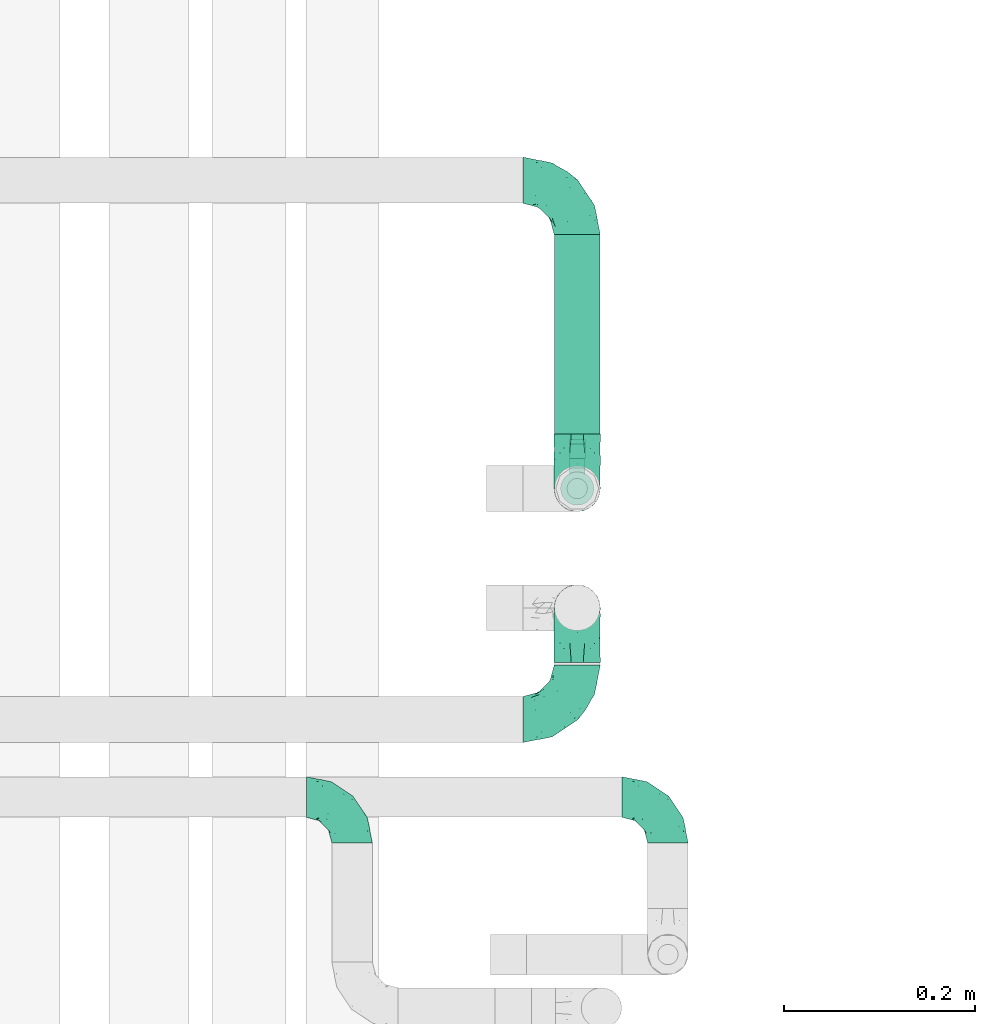
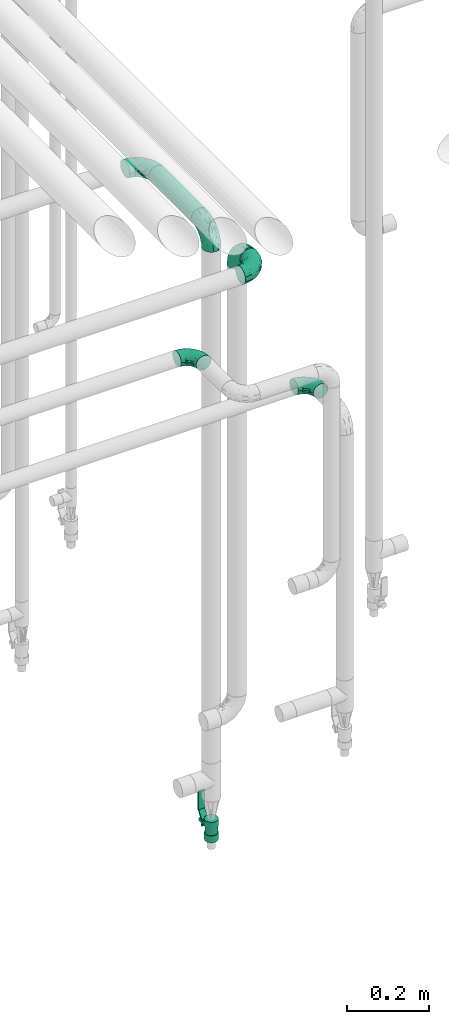
# One storey, part 577 of 827: 6 flow fittings, 1 flow controller, 1 flow segment.
"""IFC2X3 building model written with IfcOpenShell, lengths in millimetres."""

from ifc_helpers import new_model, entity, si_unit, converted_unit, derived_unit, direction, frame, origin, origin_2d_with_axis, place, context, subcontext, project, spatial, polyline, circle, outline, extrude, faceted_brep, source, transform, mapped, material, material_list, type_object, type_shapes, element, save


model = new_model("IFC2X3")

# Units and contexts
model_context = context("Model", 3, precision=0.01, world=origin(), true_north=direction((6.12303176911189e-17, 1.0)))
body_context = subcontext(model_context, "Body", "Model", "MODEL_VIEW")
ifc_project = project(units=[si_unit("LENGTHUNIT", "METRE", prefix="MILLI"), si_unit("AREAUNIT", "SQUARE_METRE"), si_unit("VOLUMEUNIT", "CUBIC_METRE"), converted_unit("PLANEANGLEUNIT", "DEGREE", entity("IfcRatioMeasure", 0.0174532925199433), si_unit("PLANEANGLEUNIT", "RADIAN"), dimensions=[0, 0, 0, 0, 0, 0, 0]), si_unit("MASSUNIT", "GRAM", prefix="KILO"), derived_unit("MASSDENSITYUNIT", [(si_unit("MASSUNIT", "GRAM", prefix="KILO"), 1), (si_unit("LENGTHUNIT", "METRE"), -3)]), derived_unit("MOMENTOFINERTIAUNIT", [(si_unit("LENGTHUNIT", "METRE"), 4)]), si_unit("TIMEUNIT", "SECOND"), si_unit("FREQUENCYUNIT", "HERTZ"), si_unit("THERMODYNAMICTEMPERATUREUNIT", "DEGREE_CELSIUS"), derived_unit("THERMALTRANSMITTANCEUNIT", [(si_unit("MASSUNIT", "GRAM", prefix="KILO"), 1), (si_unit("THERMODYNAMICTEMPERATUREUNIT", "KELVIN"), -1), (si_unit("TIMEUNIT", "SECOND"), -3)]), derived_unit("VOLUMETRICFLOWRATEUNIT", [(si_unit("LENGTHUNIT", "METRE"), 3), (si_unit("TIMEUNIT", "SECOND"), -1)]), derived_unit("MASSFLOWRATEUNIT", [(si_unit("MASSUNIT", "GRAM", prefix="KILO"), 1), (si_unit("TIMEUNIT", "SECOND"), -1)]), derived_unit("ROTATIONALFREQUENCYUNIT", [(si_unit("TIMEUNIT", "SECOND"), -1)]), si_unit("ELECTRICCURRENTUNIT", "AMPERE"), si_unit("ELECTRICVOLTAGEUNIT", "VOLT"), si_unit("POWERUNIT", "WATT"), si_unit("FORCEUNIT", "NEWTON", prefix="KILO"), si_unit("ILLUMINANCEUNIT", "LUX"), si_unit("LUMINOUSFLUXUNIT", "LUMEN"), si_unit("LUMINOUSINTENSITYUNIT", "CANDELA"), derived_unit("USERDEFINED", [(si_unit("MASSUNIT", "GRAM", prefix="KILO"), -1), (si_unit("LENGTHUNIT", "METRE"), -2), (si_unit("TIMEUNIT", "SECOND"), 3), (si_unit("LUMINOUSFLUXUNIT", "LUMEN"), 1)]), derived_unit("LINEARVELOCITYUNIT", [(si_unit("LENGTHUNIT", "METRE"), 1), (si_unit("TIMEUNIT", "SECOND"), -1)]), si_unit("PRESSUREUNIT", "PASCAL"), derived_unit("USERDEFINED", [(si_unit("LENGTHUNIT", "METRE"), -2), (si_unit("MASSUNIT", "GRAM", prefix="KILO"), 1), (si_unit("TIMEUNIT", "SECOND"), -2)]), derived_unit("LINEARFORCEUNIT", [(si_unit("MASSUNIT", "GRAM", prefix="KILO"), 1), (si_unit("LENGTHUNIT", "METRE"), 1), (si_unit("TIMEUNIT", "SECOND"), -2), (si_unit("LENGTHUNIT", "METRE"), -1)]), derived_unit("PLANARFORCEUNIT", [(si_unit("MASSUNIT", "GRAM", prefix="KILO"), 1), (si_unit("LENGTHUNIT", "METRE"), 1), (si_unit("TIMEUNIT", "SECOND"), -2), (si_unit("LENGTHUNIT", "METRE"), -2)])], contexts=[model_context])

# Site, building, storey
site_placement = place(None, origin())
site = spatial("IfcSite", under=ifc_project, at=site_placement, CompositionType="ELEMENT")
building_placement = place(site_placement, origin())
building = spatial("IfcBuilding", under=site, at=building_placement, CompositionType="ELEMENT")
storey_placement = place(building_placement, frame((0.0, 0.0, 28200.0)))
storey = spatial("IfcBuildingStorey", under=building, at=storey_placement, Name="08", CompositionType="ELEMENT", Elevation=28200.0)

# Flow segment
pipe_segment_type = type_object("IfcPipeSegmentType", PredefinedType="NOTDEFINED")
flow_segment_placement = place(storey_placement, frame((18903.46, 15687.01, 2070.34)))
element("IfcFlowSegment", 1, at=flow_segment_placement, inside=storey, type_object=pipe_segment_type, context=body_context, shape_type="SweptSolid", body=[
    extrude(circle(Radius=24.0, at=origin_2d_with_axis()), frame((25.6, 0.0, 25.6), z_axis=(0.0, 1.0, 0.0), x_axis=(1.0, 0.0, 0.0)), (0.0, 0.0, 1.0), 209.080000228861),
])

# Flow controller
ifc_material = material()
ifc_material_list = material_list([ifc_material, ifc_material, ifc_material, ifc_material, ifc_material])
valve_type = type_object("IfcValveType", PredefinedType="NOTDEFINED", material=ifc_material_list)
shared_shape_1 = source(origin(), body_context, "Body", "SweptSolid", [
    extrude(circle(Radius=17.5, at=origin_2d_with_axis()), frame((-30.5, 0.0, 0.0), z_axis=(1.0, 0.0, 0.0), x_axis=(0.0, 1.0, 0.0)), (0.0, 0.0, 1.0), 20.3333333333333),
    extrude(circle(Radius=16.0, at=origin_2d_with_axis()), frame((-10.17, 0.0, 0.0), z_axis=(1.0, 0.0, 0.0), x_axis=(0.0, 1.0, 0.0)), (0.0, 0.0, 1.0), 20.3333333333333),
    extrude(circle(Radius=17.5, at=origin_2d_with_axis()), frame((10.17, 0.0, 0.0), z_axis=(1.0, 0.0, 0.0), x_axis=(0.0, 1.0, 0.0)), (0.0, 0.0, 1.0), 20.3333333333333),
    extrude(outline(polyline([(-38.75, -5.0), (-38.75, -10.0), (-17.92, -10.0), (2.08, 5.0), (56.25, 5.0), (56.25, 10.0), (0.42, 10.0), (-19.58, -5.0), (-38.75, -5.0)])), frame((28.75, -8.75, 41.5), z_axis=(0.0, -1.0, 0.0), x_axis=(1.0, 0.0, 0.0)), (0.0, 0.0, -1.0), 17.5),
    extrude(circle(Radius=8.0, at=origin_2d_with_axis()), origin(), (0.0, 0.0, 1.0), 49.0),
])
type_shapes(valve_type, [shared_shape_1])
flow_controller_placement = place(storey_placement, frame((18929.06, 15630.01, 300.0), z_axis=(0.0, 1.0, 0.0), x_axis=(0.0, 0.0, 1.0)))
element("IfcFlowController", 2, at=flow_controller_placement, inside=storey, type_object=valve_type, material=ifc_material, context=body_context, shape_type="MappedRepresentation", body=[
    mapped(shared_shape_1, transform((0.0, 0.0, 0.0), scale=1.0)),
])

# Flow fittings
pipe_fitting_type_1 = type_object("IfcPipeFittingType", Name="ADSK_1", PredefinedType="NOTDEFINED", material=ifc_material)
shared_shape_2 = source(origin(), body_context, "Body", "Brep", [
    faceted_brep([(-57.0, 12.07, -20.91), (-57.0, 6.25, -23.33), (-57.0, 0.0, -24.15), (-57.0, -6.25, -23.33), (-57.0, -12.08, -20.91), (-57.0, -17.08, -17.08), (-57.0, -20.91, -12.08), (-57.0, -23.33, -6.25), (-57.0, -24.15, 0.0), (-57.0, -23.33, 6.25), (-57.0, -20.91, 12.07), (-57.0, -17.08, 17.08), (-57.0, -12.08, 20.91), (-57.0, -6.25, 23.33), (-57.0, 0.0, 24.15), (-57.0, 6.25, 23.33), (-57.0, 12.07, 20.91), (-57.0, 17.08, 17.08), (-57.0, 20.91, 12.07), (-57.0, 23.33, 6.25), (-57.0, 24.15, 0.0), (-57.0, 23.33, -6.25), (-57.0, 20.91, -12.08), (-57.0, 17.08, -17.08), (0.0, 57.0, -24.15), (-6.25, 57.0, -23.33), (-12.07, 57.0, -20.91), (-17.08, 57.0, -17.08), (-20.91, 57.0, -12.08), (-23.33, 57.0, -6.25), (-24.15, 57.0, 0.0), (-23.33, 57.0, 6.25), (-20.91, 57.0, 12.07), (-17.08, 57.0, 17.08), (-12.07, 57.0, 20.91), (-6.25, 57.0, 23.33), (0.0, 57.0, 24.15), (6.25, 57.0, 23.33), (12.08, 57.0, 20.91), (17.08, 57.0, 17.08), (20.91, 57.0, 12.07), (23.33, 57.0, 6.25), (24.15, 57.0, 0.0), (23.33, 57.0, -6.25), (20.91, 57.0, -12.08), (17.08, 57.0, -17.08), (12.08, 57.0, -20.91), (6.25, 57.0, -23.33), (14.9, 21.14, 6.17), (13.61, 24.64, 12.48), (6.23, 8.95, 8.98), (-41.47, -21.06, 0.0), (-41.92, -18.38, 13.72), (-24.64, -13.61, 12.48), (-37.37, -13.24, 18.15), (-6.8, -4.93, 8.18), (-21.76, -15.19, 6.22), (-12.78, -9.18, 0.0), (-37.73, -20.51, 7.75), (-7.38, 7.38, 20.24), (-23.37, -4.26, 20.42), (-11.9, -3.19, 15.86), (-42.14, -8.7, 21.82), (13.24, 37.37, 18.15), (9.33, 23.53, 16.85), (4.26, 23.37, 20.42), (2.77, 10.92, 15.55), (-29.46, 0.91, 23.52), (-44.13, 20.56, 15.69), (-39.25, 26.33, 10.88), (-49.02, 22.92, 9.96), (-34.58, 23.87, 17.15), (-15.8, 6.8, 22.81), (-8.67, 20.47, 23.88), (-18.12, 12.9, 24.08), (-48.29, 14.92, 19.65), (-44.06, -2.85, 23.78), (-9.23, 48.95, 22.58), (-3.78, 42.74, 24.07), (-40.34, 4.26, 24.09), (-44.02, 26.14, 5.46), (-44.04, 9.88, 22.74), (-4.95, 16.87, 22.52), (-2.75, 1.43, 12.5), (-25.48, 40.98, 10.71), (20.51, 37.73, 7.75), (18.38, 41.92, 13.72), (8.7, 42.14, 21.82), (-25.95, -17.97, 0.0), (2.85, 44.06, 23.78), (21.06, 41.47, 0.0), (17.97, 25.95, 0.0), (-24.04, -9.27, 17.13), (-33.26, 33.26, 5.86), (-28.55, 40.57, 0.0), (-40.57, 28.55, 0.0), (-25.29, 47.19, 4.06), (-27.01, 31.1, 16.77), (-15.7, 43.95, 19.9), (-20.27, 45.22, 15.61), (-30.53, 31.98, 12.64), (-11.28, 38.33, 22.92), (-9.97, 27.88, 24.09), (-20.15, 30.26, 21.25), (-31.25, 11.75, 23.64), (-28.75, 7.23, 24.15), (-29.53, 18.06, 22.27), (-28.44, 24.21, 20.02), (-37.55, 17.7, 20.26), (-15.88, 29.25, 22.99), (-20.82, 20.82, 23.44), (-0.91, 29.46, 23.52), (-13.5, -7.67, 12.04), (1.49, 1.56, 5.16), (8.86, 10.35, 4.59), (0.38, -0.38, 0.0), (9.18, 12.78, 0.0), (-37.37, -13.24, -18.15), (8.86, 10.35, -4.59), (-45.22, 20.27, -15.61), (-43.95, 15.7, -19.9), (-38.33, 11.28, -22.92), (-48.95, 9.23, -22.58), (-47.19, 25.29, -4.06), (-33.26, 33.26, -5.86), (18.38, 41.92, -13.72), (-30.26, 20.15, -21.25), (2.85, 44.06, -23.78), (-4.26, 40.34, -24.09), (-40.98, 25.48, -10.71), (-41.92, -18.38, -13.72), (9.25, 23.5, -16.92), (4.26, 23.37, -20.42), (13.24, 37.37, -18.15), (-37.73, -20.51, -7.75), (-11.75, 31.25, -23.64), (-7.23, 28.75, -24.15), (-12.9, 18.12, -24.08), (8.7, 42.14, -21.82), (-44.06, -2.85, -23.78), (-6.8, 15.8, -22.81), (-20.47, 8.67, -23.88), (-24.64, -13.61, -12.48), (-42.74, 3.78, -24.07), (-18.06, 29.53, -22.27), (-24.21, 28.44, -20.02), (-27.88, 9.97, -24.09), (-31.1, 27.01, -16.77), (-26.14, 44.02, -5.46), (14.9, 21.14, -6.17), (20.51, 37.73, -7.75), (-9.88, 44.04, -22.74), (-20.56, 44.13, -15.69), (-21.76, -15.19, -6.22), (-13.5, -7.67, -12.04), (-24.14, -9.76, -16.74), (-11.9, -3.19, -15.86), (-14.92, 48.29, -19.65), (-23.37, -4.26, -20.42), (-0.91, 29.46, -23.52), (-26.33, 39.25, -10.88), (-23.87, 34.58, -17.15), (-42.14, -8.7, -21.82), (-22.92, 49.02, -9.96), (13.61, 24.64, -12.48), (-31.98, 30.53, -12.64), (-16.87, 4.95, -22.52), (-17.7, 37.55, -20.26), (-29.25, 15.88, -22.99), (-20.82, 20.82, -23.44), (-29.46, 0.91, -23.52), (-7.38, 7.38, -20.24), (2.77, 10.92, -15.55), (6.23, 8.95, -8.98), (-6.8, -4.93, -8.18), (-2.81, 1.41, -12.54), (1.49, 1.56, -5.16)], [[[0, 1, 2, 3, 4, 5, 6, 7, 8, 9, 10, 11, 12, 13, 14, 15, 16, 17, 18, 19, 20, 21, 22, 23]], [[24, 25, 26, 27, 28, 29, 30, 31, 32, 33, 34, 35, 36, 37, 38, 39, 40, 41, 42, 43, 44, 45, 46, 47]], [[48, 49, 50]], [[9, 8, 51]], [[52, 53, 54]], [[55, 56, 57]], [[10, 58, 52]], [[9, 58, 10]], [[59, 60, 61]], [[54, 12, 11]], [[54, 62, 12]], [[63, 39, 38]], [[64, 65, 66]], [[62, 60, 67]], [[68, 69, 70]], [[71, 69, 68]], [[72, 73, 74]], [[16, 75, 17]], [[13, 76, 14]], [[35, 77, 78]], [[14, 79, 15]], [[17, 68, 18]], [[14, 76, 79]], [[20, 19, 80]], [[70, 19, 18]], [[81, 15, 79]], [[15, 81, 16]], [[73, 72, 82]], [[66, 83, 50]], [[32, 31, 84]], [[85, 86, 49]], [[63, 87, 65]], [[56, 58, 88]], [[36, 89, 37]], [[85, 41, 40]], [[36, 35, 78]], [[90, 41, 85]], [[40, 39, 86]], [[12, 62, 13]], [[86, 85, 40]], [[48, 85, 49]], [[85, 91, 90]], [[87, 38, 37]], [[92, 60, 54]], [[80, 69, 93]], [[93, 94, 95]], [[10, 52, 11]], [[94, 96, 30]], [[97, 98, 99]], [[80, 93, 95]], [[100, 97, 84]], [[99, 98, 33]], [[101, 102, 78]], [[103, 101, 98]], [[96, 31, 30]], [[77, 98, 101]], [[77, 35, 34]], [[34, 33, 98]], [[9, 51, 58]], [[87, 63, 38]], [[104, 105, 74]], [[106, 103, 107]], [[106, 81, 104]], [[75, 68, 17]], [[108, 107, 71]], [[33, 32, 99]], [[109, 103, 110]], [[101, 109, 102]], [[89, 78, 111]], [[53, 52, 58]], [[54, 11, 52]], [[60, 62, 54]], [[88, 58, 51]], [[76, 62, 67]], [[53, 112, 92]], [[60, 59, 72]], [[39, 63, 86]], [[49, 86, 63]], [[89, 87, 37]], [[42, 41, 90]], [[111, 82, 65]], [[111, 65, 87]], [[65, 59, 66]], [[104, 81, 79]], [[75, 81, 108]], [[32, 84, 99]], [[97, 99, 84]], [[98, 97, 103]], [[106, 107, 108]], [[74, 102, 110]], [[111, 78, 102]], [[74, 110, 104]], [[74, 67, 72]], [[61, 92, 112]], [[66, 59, 61]], [[56, 53, 58]], [[66, 50, 49]], [[61, 112, 83]], [[66, 49, 64]], [[78, 89, 36]], [[87, 89, 111]], [[62, 76, 13]], [[79, 76, 67]], [[100, 93, 69]], [[96, 93, 84]], [[55, 113, 50]], [[113, 114, 50]], [[104, 79, 105]], [[106, 104, 110]], [[20, 80, 95]], [[85, 48, 91]], [[115, 114, 113]], [[116, 91, 48]], [[70, 80, 19]], [[93, 96, 94]], [[84, 31, 96]], [[103, 106, 110]], [[81, 106, 108]], [[103, 97, 107]], [[71, 107, 97]], [[71, 97, 100]], [[108, 71, 68]], [[79, 67, 105]], [[67, 74, 105]], [[115, 113, 57]], [[112, 56, 55]], [[56, 88, 57]], [[60, 72, 67]], [[82, 72, 59]], [[65, 82, 59]], [[82, 111, 73]], [[111, 102, 73]], [[102, 74, 73]], [[81, 75, 16]], [[68, 75, 108]], [[68, 70, 18]], [[80, 70, 69]], [[98, 77, 34]], [[78, 77, 101]], [[93, 100, 84]], [[71, 100, 69]], [[102, 109, 110]], [[101, 103, 109]], [[53, 92, 54]], [[61, 60, 92]], [[56, 112, 53]], [[83, 112, 55]], [[50, 83, 55]], [[61, 83, 66]], [[49, 63, 64]], [[65, 64, 63]], [[57, 113, 55]], [[114, 115, 116]], [[116, 48, 114]], [[48, 50, 114]], [[117, 5, 4]], [[116, 115, 118]], [[119, 120, 23]], [[121, 122, 120]], [[95, 123, 20]], [[0, 23, 120]], [[124, 95, 94]], [[125, 45, 44]], [[121, 120, 126]], [[24, 127, 128]], [[22, 21, 129]], [[0, 122, 1]], [[5, 117, 130]], [[131, 132, 133]], [[134, 88, 51]], [[135, 136, 137]], [[6, 5, 130]], [[46, 138, 47]], [[139, 3, 2]], [[140, 141, 137]], [[6, 134, 7]], [[134, 130, 142]], [[143, 2, 1]], [[144, 126, 145]], [[121, 146, 143]], [[147, 120, 119]], [[94, 148, 124]], [[149, 150, 91]], [[30, 29, 148]], [[151, 25, 128]], [[27, 152, 28]], [[134, 153, 88]], [[154, 155, 156]], [[27, 26, 157]], [[151, 26, 25]], [[155, 158, 156]], [[24, 47, 127]], [[1, 122, 143]], [[138, 132, 159]], [[160, 152, 161]], [[24, 128, 25]], [[46, 133, 138]], [[162, 117, 4]], [[148, 160, 124]], [[152, 160, 163]], [[154, 142, 155]], [[45, 125, 133]], [[133, 46, 45]], [[125, 164, 133]], [[51, 7, 134]], [[42, 90, 43]], [[165, 147, 129]], [[153, 134, 142]], [[43, 150, 44]], [[162, 4, 3]], [[141, 140, 166]], [[117, 162, 158]], [[163, 29, 28]], [[43, 90, 150]], [[123, 21, 20]], [[144, 151, 135]], [[157, 152, 27]], [[167, 145, 161]], [[23, 22, 119]], [[168, 126, 169]], [[121, 168, 146]], [[139, 143, 170]], [[142, 130, 117]], [[8, 7, 51]], [[134, 6, 130]], [[139, 162, 3]], [[170, 166, 158]], [[170, 158, 162]], [[158, 171, 156]], [[44, 150, 125]], [[91, 150, 90]], [[164, 125, 150]], [[132, 138, 133]], [[127, 138, 159]], [[131, 164, 172]], [[132, 171, 140]], [[135, 151, 128]], [[157, 151, 167]], [[22, 129, 119]], [[147, 119, 129]], [[120, 147, 126]], [[144, 145, 167]], [[137, 146, 169]], [[170, 143, 146]], [[137, 169, 135]], [[137, 159, 140]], [[171, 172, 156]], [[173, 174, 175]], [[156, 175, 154]], [[174, 57, 153]], [[132, 172, 171]], [[172, 164, 173]], [[143, 139, 2]], [[162, 139, 170]], [[138, 127, 47]], [[128, 127, 159]], [[165, 124, 160]], [[123, 124, 129]], [[149, 173, 164]], [[176, 174, 173]], [[135, 128, 136]], [[144, 135, 169]], [[150, 149, 164]], [[176, 118, 115]], [[149, 91, 116]], [[30, 148, 94]], [[163, 148, 29]], [[124, 123, 95]], [[129, 21, 123]], [[126, 144, 169]], [[151, 144, 167]], [[126, 147, 145]], [[161, 145, 147]], [[161, 147, 165]], [[167, 161, 152]], [[128, 159, 136]], [[159, 137, 136]], [[154, 153, 142]], [[132, 140, 159]], [[174, 176, 57]], [[57, 88, 153]], [[166, 140, 171]], [[158, 166, 171]], [[166, 170, 141]], [[170, 146, 141]], [[146, 137, 141]], [[151, 157, 26]], [[152, 157, 167]], [[152, 163, 28]], [[148, 163, 160]], [[120, 122, 0]], [[143, 122, 121]], [[124, 165, 129]], [[161, 165, 160]], [[146, 168, 169]], [[121, 126, 168]], [[142, 117, 155]], [[158, 155, 117]], [[175, 156, 172]], [[153, 154, 174]], [[173, 175, 172]], [[174, 154, 175]], [[164, 131, 133]], [[172, 132, 131]], [[176, 173, 118]], [[57, 176, 115]], [[173, 149, 118]], [[149, 116, 118]]]),
])
type_shapes(pipe_fitting_type_1, [shared_shape_2])
for number, where, z_axis, x_axis, name in (
    (3, (18929.06, 15630.01, 2095.94), (-1.0, 0.0, 0.0), (0.0, 0.0, 1.0), "ADSK_1"),
    (4, (18929.06, 15953.09, 2095.94), (0.0, 0.0, 1.0), (0.0, 1.0, 0.0), "ADSK_1"),
    (5, (18929.06, 15505.01, 2120.94), (1.0, 0.0, 0.0), (0.0, 0.0, 1.0), "ADSK_1"),
):
    element("IfcFlowFitting", number, at=place(storey_placement, frame(where, z_axis=z_axis, x_axis=x_axis)), inside=storey, type_object=pipe_fitting_type_1, material=ifc_material, Name=name, ObjectType="ADSK_1", context=body_context, shape_type="MappedRepresentation", body=[
        mapped(shared_shape_2, transform((0.0, 0.0, 0.0), scale=1.0)),
    ])
flow_fitting_placement = place(storey_placement, frame((18929.06, 15387.98, 2120.94)))
element("IfcFlowFitting", 6, at=flow_fitting_placement, inside=storey, type_object=pipe_fitting_type_1, material=ifc_material, Name="ADSK_1", ObjectType="ADSK_1", context=body_context, shape_type="MappedRepresentation", body=[
    mapped(shared_shape_2, transform((0.0, 0.0, 0.0), scale=1.0)),
])
pipe_fitting_type_2 = type_object("IfcPipeFittingType", Name="ADSK_1", PredefinedType="NOTDEFINED", material=ifc_material)
shared_shape_3 = source(origin(), body_context, "Body", "Brep", [
    faceted_brep([(-48.0, 10.6, -18.36), (-48.0, 5.49, -20.48), (-48.0, 0.0, -21.2), (-48.0, -5.49, -20.48), (-48.0, -10.6, -18.36), (-48.0, -14.99, -14.99), (-48.0, -18.36, -10.6), (-48.0, -20.48, -5.49), (-48.0, -21.2, 0.0), (-48.0, -20.48, 5.49), (-48.0, -18.36, 10.6), (-48.0, -14.99, 14.99), (-48.0, -10.6, 18.36), (-48.0, -5.49, 20.48), (-48.0, 0.0, 21.2), (-48.0, 5.49, 20.48), (-48.0, 10.6, 18.36), (-48.0, 14.99, 14.99), (-48.0, 18.36, 10.6), (-48.0, 20.48, 5.49), (-48.0, 21.2, 0.0), (-48.0, 20.48, -5.49), (-48.0, 18.36, -10.6), (-48.0, 14.99, -14.99), (0.0, 48.0, -21.2), (-5.49, 48.0, -20.48), (-10.6, 48.0, -18.36), (-14.99, 48.0, -14.99), (-18.36, 48.0, -10.6), (-20.48, 48.0, -5.49), (-21.2, 48.0, 0.0), (-20.48, 48.0, 5.49), (-18.36, 48.0, 10.6), (-14.99, 48.0, 14.99), (-10.6, 48.0, 18.36), (-5.49, 48.0, 20.48), (0.0, 48.0, 21.2), (5.49, 48.0, 20.48), (10.6, 48.0, 18.36), (14.99, 48.0, 14.99), (18.36, 48.0, 10.6), (20.48, 48.0, 5.49), (21.2, 48.0, 0.0), (20.48, 48.0, -5.49), (18.36, 48.0, -10.6), (14.99, 48.0, -14.99), (10.6, 48.0, -18.36), (5.49, 48.0, -20.48), (-35.25, -16.22, 12.01), (-34.76, -18.57, 0.0), (-20.87, -12.37, 10.9), (-31.49, -11.78, 15.9), (-37.0, -2.58, 20.86), (-33.89, 3.62, 21.15), (-31.81, -18.14, 6.76), (-5.78, 5.78, 17.67), (-19.42, -4.1, 17.86), (-9.6, -3.39, 13.73), (-35.44, -7.73, 19.13), (11.78, 31.49, 15.9), (-5.93, -5.46, 6.95), (-18.45, -13.78, 5.46), (-10.29, -8.43, 0.0), (-24.6, 0.55, 20.62), (-37.28, 17.94, 13.81), (-33.38, 22.85, 9.59), (-41.46, 20.06, 8.75), (-29.51, 20.45, 15.16), (-15.04, 10.79, 21.13), (-7.08, 16.98, 20.93), (-8.39, 23.51, 21.15), (-40.86, 13.03, 17.26), (-8.05, 41.26, 19.83), (-3.21, 35.97, 21.14), (8.53, 19.66, 14.74), (4.1, 19.42, 17.86), (-37.72, 22.66, 4.78), (-37.07, 8.58, 19.98), (-13.0, 5.43, 19.97), (-3.78, 13.93, 19.7), (3.02, 8.69, 13.43), (-2.27, -0.05, 10.65), (6.22, 6.99, 7.09), (-22.25, 34.6, 9.45), (18.14, 31.81, 6.76), (16.22, 35.25, 12.01), (12.37, 20.87, 10.9), (7.73, 35.44, 19.13), (-21.52, -15.93, 0.0), (2.58, 37.0, 20.86), (18.57, 34.76, 0.0), (13.78, 18.45, 5.46), (15.93, 21.52, 0.0), (-20.03, -8.54, 14.9), (-28.6, 28.6, 5.16), (-24.79, 34.6, 0.0), (-34.6, 24.79, 0.0), (-22.81, 37.41, 4.68), (-23.36, 26.33, 14.79), (-13.68, 37.05, 17.49), (-17.72, 38.12, 13.73), (-26.25, 27.3, 11.24), (-9.71, 32.34, 20.14), (-17.26, 25.6, 18.71), (-26.33, 9.99, 20.77), (-24.06, 6.05, 21.2), (-25.02, 15.46, 19.56), (-24.3, 20.72, 17.57), (-31.95, 15.23, 17.8), (-13.53, 24.7, 20.21), (-17.6, 17.6, 20.6), (-0.55, 24.6, 20.62), (-11.41, -7.48, 10.43), (0.93, -0.93, 0.0), (8.43, 10.29, 0.0), (-11.41, -7.48, -10.43), (-20.1, -8.84, -14.66), (-9.6, -3.39, -13.73), (7.73, 35.44, -19.13), (4.1, 19.42, -17.86), (-0.55, 24.6, -20.62), (-38.12, 17.72, -13.73), (-37.05, 13.68, -17.49), (-32.34, 9.71, -20.14), (-41.26, 8.05, -19.83), (-37.41, 22.81, -4.68), (-23.51, 8.39, -21.15), (-35.97, 3.21, -21.14), (-28.6, 28.6, -5.16), (-31.81, -18.14, -6.76), (-18.45, -13.78, -5.46), (-25.6, 17.26, -18.71), (-19.42, -4.1, -17.86), (-17.94, 37.28, -13.81), (-22.85, 33.38, -9.59), (-20.06, 41.46, -8.75), (-31.49, -11.78, -15.9), (-35.25, -16.22, -12.01), (8.53, 19.66, -14.74), (11.78, 31.49, -15.9), (-9.99, 26.33, -20.77), (-6.05, 24.06, -21.2), (-10.79, 15.04, -21.13), (-37.0, -2.58, -20.86), (-16.98, 7.08, -20.93), (-5.43, 13.0, -19.97), (-13.93, 3.78, -19.7), (-20.87, -12.37, -10.9), (-26.33, 23.36, -14.79), (-22.66, 37.72, -4.78), (13.78, 18.45, -5.46), (18.14, 31.81, -6.76), (-15.46, 25.02, -19.56), (-20.72, 24.3, -17.57), (16.22, 35.25, -12.01), (-13.03, 40.86, -17.26), (-8.58, 37.07, -19.98), (2.58, 37.0, -20.86), (-3.62, 33.89, -21.15), (-34.6, 22.25, -9.45), (6.22, 6.99, -7.09), (-20.45, 29.51, -15.16), (-35.44, -7.73, -19.13), (12.37, 20.87, -10.9), (-27.3, 26.25, -11.24), (-15.23, 31.95, -17.8), (-24.7, 13.53, -20.21), (-24.6, 0.55, -20.62), (-5.78, 5.78, -17.67), (-17.6, 17.6, -20.6), (3.02, 8.69, -13.43), (-5.93, -5.46, -6.95), (-2.27, -0.05, -10.65)], [[[0, 1, 2, 3, 4, 5, 6, 7, 8, 9, 10, 11, 12, 13, 14, 15, 16, 17, 18, 19, 20, 21, 22, 23]], [[24, 25, 26, 27, 28, 29, 30, 31, 32, 33, 34, 35, 36, 37, 38, 39, 40, 41, 42, 43, 44, 45, 46, 47]], [[10, 48, 11]], [[9, 8, 49]], [[48, 50, 51]], [[14, 52, 53]], [[10, 54, 48]], [[9, 54, 10]], [[55, 56, 57]], [[51, 12, 11]], [[51, 58, 12]], [[59, 39, 38]], [[60, 61, 62]], [[58, 56, 63]], [[64, 65, 66]], [[67, 65, 64]], [[68, 69, 70]], [[16, 71, 17]], [[13, 52, 14]], [[35, 72, 73]], [[14, 53, 15]], [[17, 64, 18]], [[74, 59, 75]], [[20, 19, 76]], [[66, 19, 18]], [[77, 15, 53]], [[15, 77, 16]], [[69, 78, 79]], [[80, 81, 82]], [[32, 31, 83]], [[84, 85, 86]], [[59, 87, 75]], [[61, 54, 88]], [[36, 89, 37]], [[84, 41, 40]], [[36, 35, 73]], [[90, 41, 84]], [[40, 39, 85]], [[12, 58, 13]], [[85, 84, 40]], [[91, 84, 86]], [[84, 92, 90]], [[87, 38, 37]], [[93, 56, 51]], [[65, 94, 76]], [[94, 95, 96]], [[84, 91, 92]], [[95, 97, 30]], [[98, 99, 100]], [[76, 94, 96]], [[101, 98, 83]], [[100, 99, 33]], [[102, 70, 73]], [[103, 102, 99]], [[94, 97, 95]], [[72, 99, 102]], [[72, 35, 34]], [[34, 33, 99]], [[9, 49, 54]], [[87, 59, 38]], [[104, 105, 68]], [[106, 103, 107]], [[106, 77, 104]], [[71, 64, 17]], [[108, 107, 67]], [[33, 32, 100]], [[109, 103, 110]], [[102, 109, 70]], [[89, 73, 111]], [[50, 48, 54]], [[51, 11, 48]], [[56, 58, 51]], [[88, 54, 49]], [[52, 58, 63]], [[50, 112, 93]], [[56, 55, 78]], [[39, 59, 85]], [[86, 85, 59]], [[89, 87, 37]], [[42, 41, 90]], [[111, 79, 75]], [[111, 75, 87]], [[75, 55, 80]], [[104, 77, 53]], [[71, 77, 108]], [[32, 83, 100]], [[98, 100, 83]], [[99, 98, 103]], [[106, 107, 108]], [[68, 70, 110]], [[111, 73, 70]], [[68, 110, 104]], [[68, 63, 78]], [[57, 93, 112]], [[80, 55, 57]], [[61, 50, 54]], [[80, 82, 86]], [[81, 57, 112]], [[74, 86, 59]], [[60, 113, 82]], [[82, 114, 91]], [[101, 94, 65]], [[97, 94, 83]], [[73, 89, 36]], [[87, 89, 111]], [[58, 52, 13]], [[53, 52, 63]], [[104, 53, 105]], [[106, 104, 110]], [[20, 76, 96]], [[76, 19, 66]], [[103, 106, 110]], [[77, 106, 108]], [[103, 98, 107]], [[67, 107, 98]], [[67, 98, 101]], [[108, 67, 64]], [[53, 63, 105]], [[63, 68, 105]], [[83, 31, 97]], [[30, 97, 31]], [[62, 113, 60]], [[112, 61, 60]], [[61, 88, 62]], [[86, 82, 91]], [[56, 78, 63]], [[114, 82, 113]], [[114, 92, 91]], [[79, 78, 55]], [[75, 79, 55]], [[69, 79, 111]], [[70, 69, 111]], [[78, 69, 68]], [[77, 71, 16]], [[64, 71, 108]], [[64, 66, 18]], [[76, 66, 65]], [[99, 72, 34]], [[73, 72, 102]], [[94, 101, 83]], [[67, 101, 65]], [[75, 80, 74]], [[80, 86, 74]], [[70, 109, 110]], [[102, 103, 109]], [[50, 93, 51]], [[57, 56, 93]], [[61, 112, 50]], [[81, 112, 60]], [[82, 81, 60]], [[80, 57, 81]], [[115, 116, 117]], [[118, 119, 120]], [[121, 122, 23]], [[123, 124, 122]], [[96, 125, 20]], [[123, 126, 127]], [[128, 96, 95]], [[129, 130, 88]], [[123, 122, 131]], [[116, 132, 117]], [[133, 134, 135]], [[0, 124, 1]], [[5, 136, 137]], [[138, 119, 139]], [[129, 88, 49]], [[140, 141, 142]], [[6, 5, 137]], [[46, 118, 47]], [[143, 3, 2]], [[144, 145, 146]], [[6, 129, 7]], [[129, 137, 147]], [[127, 2, 1]], [[148, 122, 121]], [[128, 125, 96]], [[134, 128, 149]], [[95, 149, 128]], [[150, 151, 92]], [[30, 29, 149]], [[152, 131, 153]], [[27, 133, 28]], [[154, 45, 44]], [[136, 5, 4]], [[27, 26, 155]], [[156, 26, 25]], [[24, 157, 158]], [[24, 47, 157]], [[22, 21, 159]], [[160, 150, 114]], [[134, 133, 161]], [[142, 144, 126]], [[46, 139, 118]], [[162, 136, 4]], [[156, 25, 158]], [[1, 124, 127]], [[115, 147, 116]], [[45, 154, 139]], [[139, 46, 45]], [[154, 163, 139]], [[162, 4, 3]], [[42, 90, 43]], [[130, 129, 147]], [[49, 7, 129]], [[43, 151, 44]], [[0, 23, 122]], [[24, 158, 25]], [[136, 162, 132]], [[135, 29, 28]], [[43, 90, 151]], [[164, 148, 159]], [[152, 156, 140]], [[155, 133, 27]], [[165, 153, 161]], [[23, 22, 121]], [[123, 131, 166]], [[123, 166, 126]], [[143, 127, 167]], [[147, 137, 136]], [[8, 7, 49]], [[129, 6, 137]], [[143, 162, 3]], [[167, 146, 132]], [[167, 132, 162]], [[132, 168, 117]], [[44, 151, 154]], [[92, 151, 90]], [[163, 154, 151]], [[119, 118, 139]], [[157, 118, 120]], [[138, 139, 163]], [[119, 168, 145]], [[140, 156, 158]], [[155, 156, 165]], [[22, 159, 121]], [[148, 121, 159]], [[122, 148, 131]], [[152, 153, 165]], [[142, 126, 169]], [[167, 127, 126]], [[142, 169, 140]], [[142, 120, 145]], [[168, 170, 117]], [[160, 171, 172]], [[115, 172, 171]], [[171, 62, 130]], [[119, 170, 168]], [[170, 163, 160]], [[150, 163, 151]], [[113, 171, 160]], [[164, 128, 134]], [[125, 128, 159]], [[127, 143, 2]], [[162, 143, 167]], [[118, 157, 47]], [[158, 157, 120]], [[140, 158, 141]], [[152, 140, 169]], [[30, 149, 95]], [[149, 29, 135]], [[131, 152, 169]], [[156, 152, 165]], [[131, 148, 153]], [[161, 153, 148]], [[161, 148, 164]], [[165, 161, 133]], [[158, 120, 141]], [[120, 142, 141]], [[159, 21, 125]], [[20, 125, 21]], [[115, 130, 147]], [[114, 113, 160]], [[62, 171, 113]], [[62, 88, 130]], [[160, 163, 150]], [[150, 92, 114]], [[119, 145, 120]], [[146, 145, 168]], [[132, 146, 168]], [[144, 146, 167]], [[126, 144, 167]], [[145, 144, 142]], [[156, 155, 26]], [[133, 155, 165]], [[133, 135, 28]], [[149, 135, 134]], [[122, 124, 0]], [[127, 124, 123]], [[128, 164, 159]], [[161, 164, 134]], [[163, 170, 138]], [[170, 119, 138]], [[131, 169, 166]], [[126, 166, 169]], [[147, 136, 116]], [[132, 116, 136]], [[172, 115, 117]], [[130, 115, 171]], [[117, 170, 172]], [[160, 172, 170]]]),
])
type_shapes(pipe_fitting_type_2, [shared_shape_3])
for number, where, z_axis, x_axis, name in (
    (7, (19024.06, 15306.79, 1800.0), (0.0, 0.0, 1.0), (0.0, 1.0, 0.0), "ADSK_1"),
    (8, (18693.2, 15306.79, 2000.0), (0.0, 0.0, 1.0), (0.0, 1.0, 0.0), "ADSK_1"),
):
    element("IfcFlowFitting", number, at=place(storey_placement, frame(where, z_axis=z_axis, x_axis=x_axis)), inside=storey, type_object=pipe_fitting_type_2, material=ifc_material, Name=name, ObjectType="ADSK_1", context=body_context, shape_type="MappedRepresentation", body=[
        mapped(shared_shape_3, transform((0.0, 0.0, 0.0), scale=1.0)),
    ])

save(model, "model.ifc")
